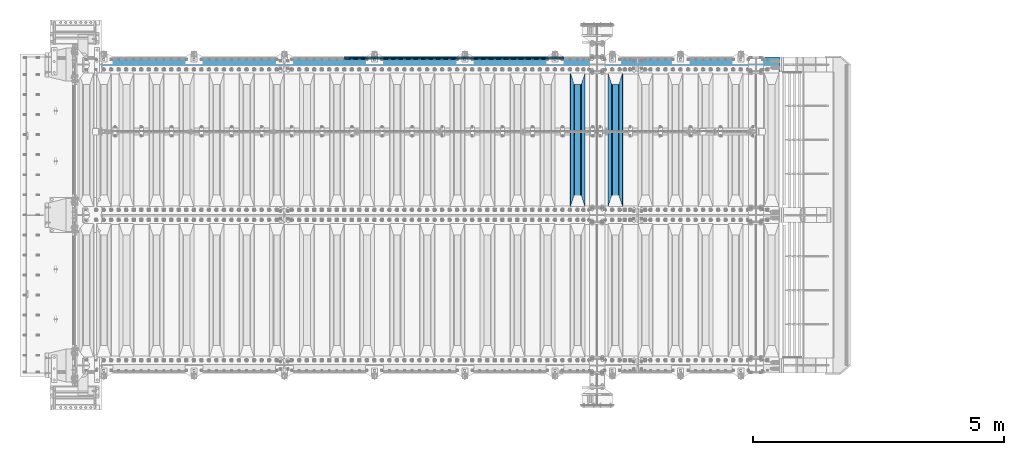
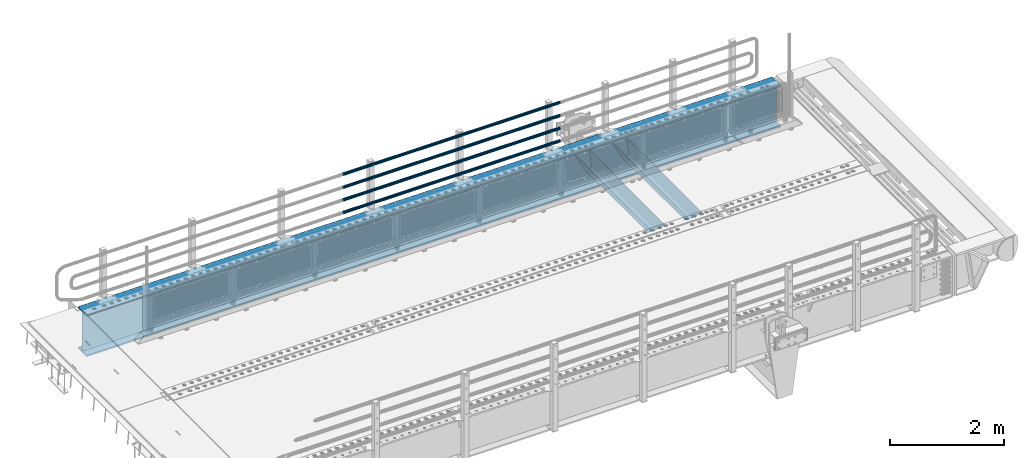
# One storey, part 99 of 193: 7 beams.
"""IFC2X3 building model written with IfcOpenShell, lengths in millimetres."""

import ifcopenshell
import ifcopenshell.guid

model = None  # the IFC model being written
_history = None  # IfcOwnerHistory: only IFC2X3 demands one
_inside = {}  # id of a spatial element -> (the spatial element, [elements in it])
_under = {}  # id of a project, library or spatial element -> (it, [spatial elements below it])
_declared = {}  # id of a project -> (the project, [libraries it declares])
_typed = {}  # id of a type object -> (the type object, [elements of that type])
_made_of = {}  # id of a material, layer set ... -> (it, [elements and type objects made of it])


def new_model(schema):
    """Start an empty IFC model of exactly this schema.

    Asked for "IFC4X3", IfcOpenShell would pick the latest addendum, in which some entities
    have other attributes; the version numbers below select the first issue.
    IFC2X3 requires an IfcOwnerHistory on every rooted entity: one is made here for all.
    """
    global model, _history
    if schema == "IFC4X3":
        model = ifcopenshell.file(schema_version=(4, 3, 0, 0))
    else:
        model = ifcopenshell.file(schema=schema)
    _inside.clear()
    _under.clear()
    _declared.clear()
    _typed.clear()
    _made_of.clear()
    _history = None
    if model.schema == "IFC2X3":
        org = make("IfcOrganization", Name="unknown")
        user = make(
            "IfcPersonAndOrganization",
            ThePerson=make("IfcPerson", FamilyName="unknown"),
            TheOrganization=org,
        )
        app = make(
            "IfcApplication",
            ApplicationDeveloper=org,
            Version="unknown",
            ApplicationFullName="unknown",
            ApplicationIdentifier="unknown",
        )
        _history = make(
            "IfcOwnerHistory",
            OwningUser=user,
            OwningApplication=app,
            ChangeAction="ADDED",
            CreationDate=0,
        )
    return model


def make(cls, **values):
    """One entity of the class cls with the attributes given. An attribute that is None is left unset."""
    return model.create_entity(
        cls, **{name: value for name, value in values.items() if value is not None}
    )


def rooted(cls, **values):
    """An entity with a GlobalId (a new one), such as an element, a storey or a relation."""
    return make(cls, GlobalId=ifcopenshell.guid.new(), OwnerHistory=_history, **values)


def si_unit(unit_type, name, prefix=None):
    """IfcSIUnit, for example si_unit("LENGTHUNIT", "METRE", prefix="MILLI")."""
    return make("IfcSIUnit", UnitType=unit_type, Prefix=prefix, Name=name)


def assignment(units):
    """IfcUnitAssignment: the units of a project."""
    return None if units is None else make("IfcUnitAssignment", Units=units)


def point(xyz):
    """IfcCartesianPoint."""
    return None if xyz is None else make("IfcCartesianPoint", Coordinates=xyz)


def direction(xyz):
    """IfcDirection."""
    return None if xyz is None else make("IfcDirection", DirectionRatios=xyz)


def frame(location, z_axis=None, x_axis=None):
    """IfcAxis2Placement3D, a coordinate frame: its origin and axes. An axis left out is left unset."""
    return make(
        "IfcAxis2Placement3D",
        Location=point(location),
        Axis=direction(z_axis),
        RefDirection=direction(x_axis),
    )


def origin_with_axes():
    """The frame at (0, 0, 0) with the z axis (0, 0, 1) and the x axis (1, 0, 0) written out."""
    return frame((0.0, 0.0, 0.0), z_axis=(0.0, 0.0, 1.0), x_axis=(1.0, 0.0, 0.0))


def place(relative_to, where):
    """IfcLocalPlacement: puts the frame where relative to a parent placement (None: the world)."""
    return make(
        "IfcLocalPlacement", PlacementRelTo=relative_to, RelativePlacement=where
    )


def context(
    kind, dimensions, precision=None, world=None, true_north=None, identifier=None
):
    """IfcGeometricRepresentationContext, for example the 3D "Model" context."""
    return make(
        "IfcGeometricRepresentationContext",
        ContextIdentifier=identifier,
        ContextType=kind,
        CoordinateSpaceDimension=dimensions,
        Precision=precision,
        WorldCoordinateSystem=world,
        TrueNorth=true_north,
    )


def subcontext(parent, identifier, kind, view, scale=None):
    """IfcGeometricRepresentationSubContext, for example "Body" below "Model"."""
    return make(
        "IfcGeometricRepresentationSubContext",
        ContextIdentifier=identifier,
        ContextType=kind,
        ParentContext=parent,
        TargetScale=scale,
        TargetView=view,
    )


def project(units=None, contexts=None):
    """IfcProject with its units and contexts."""
    return rooted(
        "IfcProject",
        Name="project",
        RepresentationContexts=contexts,
        UnitsInContext=assignment(units),
    )


def spatial(cls, under=None, at=None, **own):
    """A site, building, storey or space (cls), placed at a placement, below another one or the project."""
    s = rooted(cls, ObjectPlacement=at, **own)
    if under is not None:
        _under.setdefault(under.id(), (under, []))[1].append(s)
    return s


def faces_of(points, faces, orient=None, outer=None):
    """IfcFace entities. A face is a list of loops; a loop is a list of indices into points, from 0.

    orient and outer hold one flag for each loop. By default every Orientation is true, the
    first loop of a face is its IfcFaceOuterBound and the others are IfcFaceBound.
    """
    made = []
    for i, loops in enumerate(faces):
        bounds = []
        for j, loop in enumerate(loops):
            is_outer = j == 0 if outer is None else outer[i][j]
            bounds.append(
                make(
                    "IfcFaceOuterBound" if is_outer else "IfcFaceBound",
                    Bound=make("IfcPolyLoop", Polygon=[points[k] for k in loop]),
                    Orientation=True if orient is None else orient[i][j],
                )
            )
        made.append(make("IfcFace", Bounds=bounds))
    return made


def faceted_brep(points, faces, orient=None, outer=None, voids=None):
    """IfcFacetedBrep: a solid bounded by flat faces; with voids (closed shells), ...WithVoids."""
    shared = [point(p) for p in points]
    hull = make("IfcClosedShell", CfsFaces=faces_of(shared, faces, orient, outer))
    if voids is None:
        return make("IfcFacetedBrep", Outer=hull)
    return make(
        "IfcFacetedBrepWithVoids",
        Outer=hull,
        Voids=[
            make(cls, CfsFaces=faces_of(shared, fs, o, b)) for cls, fs, o, b in voids
        ],
    )


def shape(context_of_items, identifier, shape_type, items):
    """IfcShapeRepresentation: the items that make up one representation, for example the "Body"."""
    return make(
        "IfcShapeRepresentation",
        ContextOfItems=context_of_items,
        RepresentationIdentifier=identifier,
        RepresentationType=shape_type,
        Items=items,
    )


def material(Name=None, Category=None):
    """IfcMaterial."""
    return make("IfcMaterial", Name=Name, Category=Category)


def made_of(thing, what):
    """Note that an element or type object is made of a material, layer set ...; save() writes the relation."""
    if what is not None:
        _made_of.setdefault(what.id(), (what, []))[1].append(thing)
    return thing


def type_object(cls, material=None, **own):
    """A type object (cls), such as IfcWallType, which elements share."""
    return made_of(rooted(cls, **own), material)


def element(
    cls,
    number,
    at=None,
    inside=None,
    cuts=None,
    type_object=None,
    material=None,
    context=None,
    identifier="Body",
    shape_type=None,
    held_by="IfcProductDefinitionShape",
    body=None,
    shapes=None,
    **own,
):
    """One element of the class cls, such as IfcWall. Its Tag is "e" and its number.

    at: its placement. inside: the storey or other place that contains it. cuts: it is an
    opening in that element (IfcRelVoidsElement). A single representation is given by context,
    identifier, shape_type and body (its items); several are given by shapes. held_by: the class
    of the entity that holds the representations. save() writes the other relations.
    """
    e = rooted(cls, Tag="e%d" % number, ObjectPlacement=at, **own)
    if body is not None:
        shapes = [shape(context, identifier, shape_type, body)]
    if shapes is not None:
        e.Representation = make(held_by, Representations=shapes)
    if inside is not None:
        _inside.setdefault(inside.id(), (inside, []))[1].append(e)
    if cuts is not None:
        rooted(
            "IfcRelVoidsElement", RelatingBuildingElement=cuts, RelatedOpeningElement=e
        )
    if type_object is not None:
        _typed.setdefault(type_object.id(), (type_object, []))[1].append(e)
    return made_of(e, material)


def aggregate(whole, parts):
    """IfcRelAggregates: a whole, such as a stair, and the parts it consists of."""
    return rooted("IfcRelAggregates", RelatingObject=whole, RelatedObjects=parts)


def save(model, path):
    """Write the relations noted so far, then the file.

    IfcRelAggregates (storeys below a building ...), IfcRelContainedInSpatialStructure (elements
    in a storey), IfcRelDefinesByType, IfcRelAssociatesMaterial and IfcRelDeclares: one each for
    every whole, place, type object, material and project.
    """
    for whole, parts in _under.values():
        aggregate(whole, parts)
    for where, things in _inside.values():
        rooted(
            "IfcRelContainedInSpatialStructure",
            RelatedElements=things,
            RelatingStructure=where,
        )
    for kind, things in _typed.values():
        rooted("IfcRelDefinesByType", RelatedObjects=things, RelatingType=kind)
    for what, things in _made_of.values():
        rooted("IfcRelAssociatesMaterial", RelatedObjects=things, RelatingMaterial=what)
    for by, libraries in _declared.values():
        rooted("IfcRelDeclares", RelatingContext=by, RelatedDefinitions=libraries)
    model.write(path)


model = new_model("IFC2X3")

# Units and contexts
model_context = context("Model", 3, precision=1e-05, world=origin_with_axes())
body_context = subcontext(model_context, "Body", "Model", "MODEL_VIEW")
ifc_project = project(units=[si_unit("LENGTHUNIT", "METRE", prefix="MILLI"), si_unit("AREAUNIT", "SQUARE_METRE"), si_unit("VOLUMEUNIT", "CUBIC_METRE"), si_unit("MASSUNIT", "GRAM", prefix="KILO"), si_unit("TIMEUNIT", "SECOND"), si_unit("PLANEANGLEUNIT", "RADIAN"), si_unit("SOLIDANGLEUNIT", "STERADIAN"), si_unit("THERMODYNAMICTEMPERATUREUNIT", "DEGREE_CELSIUS"), si_unit("LUMINOUSINTENSITYUNIT", "LUMEN")], contexts=[model_context])

# Site, building, storey
site_placement = place(None, origin_with_axes())
site = spatial("IfcSite", under=ifc_project, at=site_placement, CompositionType="ELEMENT")
building_placement = place(site_placement, origin_with_axes())
building = spatial("IfcBuilding", under=site, at=building_placement, Name="Standard", CompositionType="ELEMENT")
storey_placement = place(building_placement, origin_with_axes())
storey = spatial("IfcBuildingStorey", under=building, at=storey_placement, Name="Undefined", CompositionType="ELEMENT", Elevation=0.0)

# Beams
ifc_material_1 = material(Name="STEEL/S355N")
beam_type_1 = type_object("IfcBeamType", PredefinedType="NOTDEFINED")
beam_1_placement = place(storey_placement, frame((-31700.0, 27175.0, -115.0), z_axis=(0.0, 0.0, 1.0), x_axis=(0.0, 1.0, 0.0)))
element("IfcBeam", 1, at=beam_1_placement, inside=storey, type_object=beam_type_1, material=ifc_material_1, context=body_context, shape_type="Brep", body=[
    faceted_brep([(0.0, 150.0, 115.0), (0.0, 143.689999999999, 115.0), (2650.00000000297, 143.689999999999, 115.0), (2650.00000000297, 150.0, 115.0), (2650.00000000297, 142.059565218398, 110.000000003094), (2650.00000000297, 148.3695652184, 110.000000003094), (2441.90079219209, -80.1103600731112, -98.0992078077845), (2437.7588105432, -77.5672621345584, -102.241189456673), (2434.06523489747, -74.4080125315522, -105.934765102404), (2430.9108609509, -70.710272125576, -109.089139048974), (2428.37322971128, -66.5649389910068, -111.626770288588), (2426.51472138055, -62.0739139532889, -113.485278619323), (2425.38102192092, -57.3475956567672, -114.618978078955), (2424.99999999988, -52.5021667386536, -115.0), (2424.99999999988, 52.5021667386536, -115.0), (2425.38102192092, 57.3475956567672, -114.618978078955), (2426.51472138055, 62.0739139532889, -113.485278619323), (2428.37322971128, 66.5649389910068, -111.626770288588), (2430.9108609509, 70.710272125576, -109.089139048974), (2434.06523489747, 74.4080125315522, -105.934765102404), (2437.7588105432, 77.5672621345584, -102.241189456673), (2441.90079219209, 80.1103600731112, -98.0992078077846), (2446.38936140512, 81.9747917625791, -93.6106385947584), (2448.2494850041, 76.2713538057251, -91.7505149957729), (2444.62967112263, 74.76777986261, -95.3703288772456), (2441.28936334127, 72.7168944282894, -98.710636658607), (2438.31067330439, 70.1691124903846, -101.689326695487), (2435.76682334748, 67.1870637758839, -104.233176652398), (2433.72034654134, 63.8440531834895, -106.279653458539), (2432.22154950042, 60.222258798236, -107.778450499454), (2431.30727574265, 56.4107117849089, -108.692724257221), (2430.99999999987, 52.5031078186876, -109.0), (2430.99999999987, -52.5031078186876, -109.0), (2431.30727574265, -56.4107117849089, -108.692724257221), (2432.22154950042, -60.222258798236, -107.778450499454), (2433.72034654134, -63.8440531834895, -106.279653458539), (2435.76682334748, -67.1870637758839, -104.233176652398), (2438.31067330439, -70.1691124903846, -101.689326695487), (2441.28936334127, -72.7168944282894, -98.7106366586071), (2444.62967112263, -74.76777986261, -95.3703288772457), (2448.2494850041, -76.2713538057251, -91.7505149957729), (2650.00000000297, -142.059565218398, 110.000000003094), (2650.00000000297, -148.3695652184, 110.000000003094), (2446.38936140512, -81.9747917625791, -93.6106385947584), (2650.00000000297, -143.689999999999, 115.0), (2650.00000000297, -150.0, 115.0), (0.0, -143.689999999999, 115.0), (0.0, -150.0, 115.0), (0.0, -148.369565218261, 110.000000002667), (203.610638597427, -81.9747917625791, -93.6106385947584), (208.099207810446, -80.1103600731112, -98.0992078077845), (212.241189459342, -77.5672621345584, -102.241189456673), (215.93476510507, -74.4080125315522, -105.934765102404), (219.089139051641, -70.710272125576, -109.089139048974), (221.626770291256, -66.5649389910068, -111.626770288588), (223.485278621989, -62.0739139532889, -113.485278619323), (224.618978081624, -57.3475956567672, -114.618978078955), (225.000000002663, -52.5021667386536, -115.0), (225.000000002663, 52.5021667386536, -115.0), (224.618978081624, 57.3475956567672, -114.618978078955), (223.485278621989, 62.0739139532889, -113.485278619323), (221.626770291256, 66.5649389910068, -111.626770288588), (219.089139051641, 70.710272125576, -109.089139048974), (215.93476510507, 74.4080125315522, -105.934765102404), (212.241189459342, 77.5672621345584, -102.241189456673), (208.099207810446, 80.1103600731112, -98.0992078077846), (203.610638597427, 81.9747917625791, -93.6106385947584), (0.0, 148.369565218261, 110.000000002667), (0.0, 142.05956521826, 110.000000002667), (201.750514998439, 76.2713538057251, -91.7505149957729), (205.370328879915, 74.76777986261, -95.3703288772456), (208.710636661275, 72.7168944282894, -98.710636658607), (211.689326698157, 70.1691124903846, -101.689326695487), (214.233176655063, 67.1870637758839, -104.233176652398), (216.279653461206, 63.8440531834895, -106.279653458539), (217.778450502123, 60.222258798236, -107.778450499454), (218.69272425989, 56.4107117849089, -108.692724257221), (219.00000000267, 52.5031078186876, -109.0), (219.00000000267, -52.5031078186876, -109.0), (218.69272425989, -56.4107117849089, -108.692724257221), (217.778450502123, -60.222258798236, -107.778450499454), (216.279653461206, -63.8440531834895, -106.279653458539), (214.233176655063, -67.1870637758839, -104.233176652398), (211.689326698157, -70.1691124903846, -101.689326695487), (208.710636661275, -72.7168944282894, -98.7106366586071), (205.370328879915, -74.76777986261, -95.3703288772457), (201.750514998439, -76.2713538057251, -91.7505149957729), (0.0, -142.05956521826, 110.000000002667)], [[[0, 1, 2, 3]], [[3, 2, 4, 5]], [[6, 7, 8, 9, 10, 11, 12, 13, 14, 15, 16, 17, 18, 19, 20, 21, 22, 5, 4, 23, 24, 25, 26, 27, 28, 29, 30, 31, 32, 33, 34, 35, 36, 37, 38, 39, 40, 41, 42, 43]], [[44, 45, 42, 41]], [[46, 47, 45, 44]], [[43, 42, 45, 47, 48, 49]], [[6, 43, 49, 50]], [[7, 6, 50, 51]], [[8, 7, 51, 52]], [[9, 8, 52, 53]], [[10, 9, 53, 54]], [[11, 10, 54, 55]], [[12, 11, 55, 56]], [[13, 12, 56, 57]], [[14, 13, 57, 58]], [[15, 14, 58, 59]], [[16, 15, 59, 60]], [[17, 16, 60, 61]], [[18, 17, 61, 62]], [[19, 18, 62, 63]], [[20, 19, 63, 64]], [[21, 20, 64, 65]], [[22, 21, 65, 66]], [[0, 3, 5, 22, 66, 67]], [[1, 0, 67, 68]], [[23, 4, 2, 1, 68, 69]], [[24, 23, 69, 70]], [[25, 24, 70, 71]], [[26, 25, 71, 72]], [[27, 26, 72, 73]], [[28, 27, 73, 74]], [[29, 28, 74, 75]], [[30, 29, 75, 76]], [[31, 30, 76, 77]], [[32, 31, 77, 78]], [[33, 32, 78, 79]], [[34, 33, 79, 80]], [[35, 34, 80, 81]], [[36, 35, 81, 82]], [[37, 36, 82, 83]], [[38, 37, 83, 84]], [[39, 38, 84, 85]], [[40, 39, 85, 86]], [[46, 44, 41, 40, 86, 87]], [[47, 46, 87, 48]], [[86, 85, 84, 83, 82, 81, 80, 79, 78, 77, 76, 75, 74, 73, 72, 71, 70, 69, 68, 67, 66, 65, 64, 63, 62, 61, 60, 59, 58, 57, 56, 55, 54, 53, 52, 51, 50, 49, 48, 87]]]),
])
beam_2_placement = place(storey_placement, frame((-32450.0, 27175.0, -115.0), z_axis=(0.0, 0.0, 1.0), x_axis=(0.0, 1.0, 0.0)))
element("IfcBeam", 2, at=beam_2_placement, inside=storey, type_object=beam_type_1, material=ifc_material_1, context=body_context, shape_type="Brep", body=[
    faceted_brep([(0.0, 150.0, 115.0), (0.0, 143.689999999999, 115.0), (2650.00000000297, 143.689999999999, 115.0), (2650.00000000297, 150.0, 115.0), (2650.00000000297, 142.059565218398, 110.000000003094), (2650.00000000297, 148.3695652184, 110.000000003094), (2441.90079219209, -80.1103600731112, -98.0992078077845), (2437.7588105432, -77.5672621345584, -102.241189456673), (2434.06523489747, -74.4080125315522, -105.934765102404), (2430.9108609509, -70.710272125576, -109.089139048974), (2428.37322971128, -66.5649389910068, -111.626770288588), (2426.51472138055, -62.0739139532889, -113.485278619323), (2425.38102192092, -57.3475956567672, -114.618978078955), (2424.99999999988, -52.5021667386536, -115.0), (2424.99999999988, 52.5021667386536, -115.0), (2425.38102192092, 57.3475956567672, -114.618978078955), (2426.51472138055, 62.0739139532889, -113.485278619323), (2428.37322971128, 66.5649389910068, -111.626770288588), (2430.9108609509, 70.710272125576, -109.089139048974), (2434.06523489747, 74.4080125315522, -105.934765102404), (2437.7588105432, 77.5672621345584, -102.241189456673), (2441.90079219209, 80.1103600731112, -98.0992078077846), (2446.38936140512, 81.9747917625791, -93.6106385947584), (2448.2494850041, 76.2713538057251, -91.7505149957729), (2444.62967112263, 74.76777986261, -95.3703288772456), (2441.28936334127, 72.7168944282894, -98.710636658607), (2438.31067330439, 70.1691124903846, -101.689326695487), (2435.76682334748, 67.1870637758839, -104.233176652398), (2433.72034654134, 63.8440531834895, -106.279653458539), (2432.22154950042, 60.222258798236, -107.778450499454), (2431.30727574265, 56.4107117849089, -108.692724257221), (2430.99999999987, 52.5031078186876, -109.0), (2430.99999999987, -52.5031078186876, -109.0), (2431.30727574265, -56.4107117849089, -108.692724257221), (2432.22154950042, -60.222258798236, -107.778450499454), (2433.72034654134, -63.8440531834895, -106.279653458539), (2435.76682334748, -67.1870637758839, -104.233176652398), (2438.31067330439, -70.1691124903846, -101.689326695487), (2441.28936334127, -72.7168944282894, -98.7106366586071), (2444.62967112263, -74.76777986261, -95.3703288772457), (2448.2494850041, -76.2713538057251, -91.7505149957729), (2650.00000000297, -142.059565218398, 110.000000003094), (2650.00000000297, -148.3695652184, 110.000000003094), (2446.38936140512, -81.9747917625791, -93.6106385947584), (2650.00000000297, -143.689999999999, 115.0), (2650.00000000297, -150.0, 115.0), (0.0, -143.689999999999, 115.0), (0.0, -150.0, 115.0), (0.0, -148.369565218261, 110.000000002667), (203.610638597427, -81.9747917625791, -93.6106385947584), (208.099207810446, -80.1103600731112, -98.0992078077845), (212.241189459342, -77.5672621345584, -102.241189456673), (215.93476510507, -74.4080125315522, -105.934765102404), (219.089139051641, -70.710272125576, -109.089139048974), (221.626770291256, -66.5649389910068, -111.626770288588), (223.485278621989, -62.0739139532889, -113.485278619323), (224.618978081624, -57.3475956567672, -114.618978078955), (225.000000002663, -52.5021667386536, -115.0), (225.000000002663, 52.5021667386536, -115.0), (224.618978081624, 57.3475956567672, -114.618978078955), (223.485278621989, 62.0739139532889, -113.485278619323), (221.626770291256, 66.5649389910068, -111.626770288588), (219.089139051641, 70.710272125576, -109.089139048974), (215.93476510507, 74.4080125315522, -105.934765102404), (212.241189459342, 77.5672621345584, -102.241189456673), (208.099207810446, 80.1103600731112, -98.0992078077846), (203.610638597427, 81.9747917625791, -93.6106385947584), (0.0, 148.369565218261, 110.000000002667), (0.0, 142.05956521826, 110.000000002667), (201.750514998439, 76.2713538057251, -91.7505149957729), (205.370328879915, 74.76777986261, -95.3703288772456), (208.710636661275, 72.7168944282894, -98.710636658607), (211.689326698157, 70.1691124903846, -101.689326695487), (214.233176655063, 67.1870637758839, -104.233176652398), (216.279653461206, 63.8440531834895, -106.279653458539), (217.778450502123, 60.222258798236, -107.778450499454), (218.69272425989, 56.4107117849089, -108.692724257221), (219.00000000267, 52.5031078186876, -109.0), (219.00000000267, -52.5031078186876, -109.0), (218.69272425989, -56.4107117849089, -108.692724257221), (217.778450502123, -60.222258798236, -107.778450499454), (216.279653461206, -63.8440531834895, -106.279653458539), (214.233176655063, -67.1870637758839, -104.233176652398), (211.689326698157, -70.1691124903846, -101.689326695487), (208.710636661275, -72.7168944282894, -98.7106366586071), (205.370328879915, -74.76777986261, -95.3703288772457), (201.750514998439, -76.2713538057251, -91.7505149957729), (0.0, -142.05956521826, 110.000000002667)], [[[0, 1, 2, 3]], [[3, 2, 4, 5]], [[6, 7, 8, 9, 10, 11, 12, 13, 14, 15, 16, 17, 18, 19, 20, 21, 22, 5, 4, 23, 24, 25, 26, 27, 28, 29, 30, 31, 32, 33, 34, 35, 36, 37, 38, 39, 40, 41, 42, 43]], [[44, 45, 42, 41]], [[46, 47, 45, 44]], [[43, 42, 45, 47, 48, 49]], [[6, 43, 49, 50]], [[7, 6, 50, 51]], [[8, 7, 51, 52]], [[9, 8, 52, 53]], [[10, 9, 53, 54]], [[11, 10, 54, 55]], [[12, 11, 55, 56]], [[13, 12, 56, 57]], [[14, 13, 57, 58]], [[15, 14, 58, 59]], [[16, 15, 59, 60]], [[17, 16, 60, 61]], [[18, 17, 61, 62]], [[19, 18, 62, 63]], [[20, 19, 63, 64]], [[21, 20, 64, 65]], [[22, 21, 65, 66]], [[0, 3, 5, 22, 66, 67]], [[1, 0, 67, 68]], [[23, 4, 2, 1, 68, 69]], [[24, 23, 69, 70]], [[25, 24, 70, 71]], [[26, 25, 71, 72]], [[27, 26, 72, 73]], [[28, 27, 73, 74]], [[29, 28, 74, 75]], [[30, 29, 75, 76]], [[31, 30, 76, 77]], [[32, 31, 77, 78]], [[33, 32, 78, 79]], [[34, 33, 79, 80]], [[35, 34, 80, 81]], [[36, 35, 81, 82]], [[37, 36, 82, 83]], [[38, 37, 83, 84]], [[39, 38, 84, 85]], [[40, 39, 85, 86]], [[46, 44, 41, 40, 86, 87]], [[47, 46, 87, 48]], [[86, 85, 84, 83, 82, 81, 80, 79, 78, 77, 76, 75, 74, 73, 72, 71, 70, 69, 68, 67, 66, 65, 64, 63, 62, 61, 60, 59, 58, 57, 56, 55, 54, 53, 52, 51, 50, 49, 48, 87]]]),
])
ifc_material_2 = material()
beam_type_2 = type_object("IfcBeamType", PredefinedType="NOTDEFINED")
beam_3_placement = place(storey_placement, frame((-32722.0000000001, 30129.8500000001, 149.849999999748), z_axis=(0.0, 0.0, -1.0), x_axis=(-1.0, 0.0, 0.0)))
element("IfcBeam", 3, at=beam_3_placement, inside=storey, type_object=beam_type_2, material=ifc_material_2, context=body_context, shape_type="Brep", body=[
    faceted_brep([(0.0, -26.5499999999993, 0.0), (0.0, -24.5290015881765, 10.1602451292931), (4384.00249699992, -24.5290015881765, 10.1602451292931), (4384.00249699992, -26.5499999999993, 0.0), (0.0, -18.7736850405017, 18.7736850405028), (4384.00249699992, -18.7736850405017, 18.7736850405028), (0.0, -10.1602451292929, 24.5290015881747), (4384.00249699992, -10.1602451292929, 24.5290015881747), (0.0, 0.0, 26.55), (4384.00249699992, 0.0, 26.55), (0.0, 10.1602451292929, 24.5290015881747), (4384.00249699992, 10.1602451292929, 24.5290015881747), (0.0, 18.7736850405017, 18.7736850405028), (4384.00249699992, 18.7736850405017, 18.7736850405028), (0.0, 24.5290015881765, 10.1602451292931), (4384.00249699992, 24.5290015881765, 10.1602451292931), (0.0, 26.5499999999993, 0.0), (4384.00249699992, 26.5499999999993, 0.0), (0.0, 24.5290015881765, -10.1602451292931), (4384.00249699992, 24.5290015881765, -10.1602451292931), (0.0, 18.7736850405017, -18.7736850405028), (4384.00249699992, 18.7736850405017, -18.7736850405028), (0.0, 10.1602451292929, -24.5290015881747), (4384.00249699992, 10.1602451292929, -24.5290015881747), (0.0, 0.0, -26.55), (4384.00249699992, 0.0, -26.55), (0.0, -10.1602451292929, -24.5290015881747), (4384.00249699992, -10.1602451292929, -24.5290015881747), (0.0, -18.7736850405017, -18.7736850405028), (4384.00249699992, -18.7736850405017, -18.7736850405028), (0.0, -24.5290015881765, -10.1602451292931), (4384.00249699992, -24.5290015881765, -10.1602451292931), (0.0, -30.1500000000015, 0.0), (0.0, -27.8549679052157, -11.5379054858058), (4384.00249699992, -27.8549679052157, -11.5379054858075), (4384.00249699992, -30.1500000000015, 0.0), (0.0, -21.3192694527752, -21.3192694527752), (4384.00249699992, -21.3192694527752, -21.3192694527744), (0.0, -11.5379054858058, -27.8549679052157), (4384.00249699992, -11.5379054858058, -27.8549679052153), (0.0, 0.0, -30.1500000000015), (4384.00249699992, 0.0, -30.15), (0.0, 11.5379054858058, -27.8549679052157), (4384.00249699992, 11.5379054858058, -27.8549679052153), (0.0, 21.3192694527752, -21.3192694527752), (4384.00249699992, 21.3192694527752, -21.3192694527744), (0.0, 27.8549679052157, -11.5379054858058), (4384.00249699992, 27.8549679052157, -11.5379054858074), (0.0, 30.1500000000015, 0.0), (4384.00249699992, 30.1500000000015, 0.0), (0.0, 27.8549679052157, 11.5379054858058), (4384.00249699992, 27.8549679052157, 11.5379054858075), (0.0, 21.3192694527752, 21.3192694527752), (4384.00249699992, 21.3192694527752, 21.3192694527744), (0.0, 11.5379054858058, 27.8549679052157), (4384.00249699992, 11.5379054858058, 27.8549679052153), (0.0, 0.0, 30.1500000000015), (4384.00249699992, 0.0, 30.15), (0.0, -11.5379054858058, 27.8549679052157), (4384.00249699992, -11.5379054858058, 27.8549679052153), (0.0, -21.3192694527752, 21.3192694527752), (4384.00249699992, -21.3192694527752, 21.3192694527744), (0.0, -27.8549679052157, 11.5379054858058), (4384.00249699992, -27.8549679052157, 11.5379054858075)], [[[0, 1, 2, 3]], [[1, 4, 5, 2]], [[4, 6, 7, 5]], [[6, 8, 9, 7]], [[8, 10, 11, 9]], [[10, 12, 13, 11]], [[12, 14, 15, 13]], [[14, 16, 17, 15]], [[16, 18, 19, 17]], [[18, 20, 21, 19]], [[20, 22, 23, 21]], [[22, 24, 25, 23]], [[24, 26, 27, 25]], [[26, 28, 29, 27]], [[28, 30, 31, 29]], [[30, 0, 3, 31]], [[32, 33, 34, 35]], [[33, 36, 37, 34]], [[36, 38, 39, 37]], [[38, 40, 41, 39]], [[40, 42, 43, 41]], [[42, 44, 45, 43]], [[44, 46, 47, 45]], [[46, 48, 49, 47]], [[48, 50, 51, 49]], [[50, 52, 53, 51]], [[52, 54, 55, 53]], [[54, 56, 57, 55]], [[56, 58, 59, 57]], [[58, 60, 61, 59]], [[60, 62, 63, 61]], [[62, 32, 35, 63]], [[37, 39, 41, 43, 45, 47, 49, 51, 53, 55, 57, 59, 61, 63, 35, 34], [5, 7, 9, 11, 13, 15, 17, 19, 21, 23, 25, 27, 29, 31, 3, 2]], [[62, 60, 58, 56, 54, 52, 50, 48, 46, 44, 42, 40, 38, 36, 33, 32], [30, 28, 26, 24, 22, 20, 18, 16, 14, 12, 10, 8, 6, 4, 1, 0]]]),
])
beam_4_placement = place(storey_placement, frame((-32722.0000000001, 30129.8500000001, 420.149999999748), z_axis=(0.0, 0.0, -1.0), x_axis=(-1.0, 0.0, 0.0)))
element("IfcBeam", 4, at=beam_4_placement, inside=storey, type_object=beam_type_2, material=ifc_material_2, context=body_context, shape_type="Brep", body=[
    faceted_brep([(0.0, -26.5499999999993, 0.0), (0.0, -24.5290015881765, 10.1602451292931), (4384.00249699992, -24.5290015881765, 10.1602451292931), (4384.00249699992, -26.5499999999993, 0.0), (0.0, -18.7736850405017, 18.7736850405028), (4384.00249699992, -18.7736850405017, 18.7736850405028), (0.0, -10.1602451292929, 24.5290015881747), (4384.00249699992, -10.1602451292929, 24.5290015881747), (0.0, 0.0, 26.55), (4384.00249699992, 0.0, 26.55), (0.0, 10.1602451292929, 24.5290015881747), (4384.00249699992, 10.1602451292929, 24.5290015881747), (0.0, 18.7736850405017, 18.7736850405028), (4384.00249699992, 18.7736850405017, 18.7736850405028), (0.0, 24.5290015881765, 10.1602451292931), (4384.00249699992, 24.5290015881765, 10.1602451292931), (0.0, 26.5499999999993, 0.0), (4384.00249699992, 26.5499999999993, 0.0), (0.0, 24.5290015881765, -10.1602451292931), (4384.00249699992, 24.5290015881765, -10.1602451292931), (0.0, 18.7736850405017, -18.7736850405028), (4384.00249699992, 18.7736850405017, -18.7736850405028), (0.0, 10.1602451292929, -24.5290015881747), (4384.00249699992, 10.1602451292929, -24.5290015881747), (0.0, 0.0, -26.55), (4384.00249699992, 0.0, -26.55), (0.0, -10.1602451292929, -24.5290015881747), (4384.00249699992, -10.1602451292929, -24.5290015881747), (0.0, -18.7736850405017, -18.7736850405028), (4384.00249699992, -18.7736850405017, -18.7736850405028), (0.0, -24.5290015881765, -10.1602451292931), (4384.00249699992, -24.5290015881765, -10.1602451292931), (0.0, -30.1500000000015, 0.0), (0.0, -27.8549679052157, -11.5379054858058), (4384.00249699992, -27.8549679052157, -11.5379054858075), (4384.00249699992, -30.1500000000015, 0.0), (0.0, -21.3192694527752, -21.3192694527752), (4384.00249699992, -21.3192694527752, -21.3192694527744), (0.0, -11.5379054858058, -27.8549679052157), (4384.00249699992, -11.5379054858058, -27.8549679052153), (0.0, 0.0, -30.1500000000015), (4384.00249699992, 0.0, -30.15), (0.0, 11.5379054858058, -27.8549679052157), (4384.00249699992, 11.5379054858058, -27.8549679052153), (0.0, 21.3192694527752, -21.3192694527752), (4384.00249699992, 21.3192694527752, -21.3192694527744), (0.0, 27.8549679052157, -11.5379054858058), (4384.00249699992, 27.8549679052157, -11.5379054858074), (0.0, 30.1500000000015, 0.0), (4384.00249699992, 30.1500000000015, 0.0), (0.0, 27.8549679052157, 11.5379054858058), (4384.00249699992, 27.8549679052157, 11.5379054858075), (0.0, 21.3192694527752, 21.3192694527752), (4384.00249699992, 21.3192694527752, 21.3192694527744), (0.0, 11.5379054858058, 27.8549679052157), (4384.00249699992, 11.5379054858058, 27.8549679052153), (0.0, 0.0, 30.1500000000015), (4384.00249699992, 0.0, 30.15), (0.0, -11.5379054858058, 27.8549679052157), (4384.00249699992, -11.5379054858058, 27.8549679052153), (0.0, -21.3192694527752, 21.3192694527752), (4384.00249699992, -21.3192694527752, 21.3192694527744), (0.0, -27.8549679052157, 11.5379054858058), (4384.00249699992, -27.8549679052157, 11.5379054858075)], [[[0, 1, 2, 3]], [[1, 4, 5, 2]], [[4, 6, 7, 5]], [[6, 8, 9, 7]], [[8, 10, 11, 9]], [[10, 12, 13, 11]], [[12, 14, 15, 13]], [[14, 16, 17, 15]], [[16, 18, 19, 17]], [[18, 20, 21, 19]], [[20, 22, 23, 21]], [[22, 24, 25, 23]], [[24, 26, 27, 25]], [[26, 28, 29, 27]], [[28, 30, 31, 29]], [[30, 0, 3, 31]], [[32, 33, 34, 35]], [[33, 36, 37, 34]], [[36, 38, 39, 37]], [[38, 40, 41, 39]], [[40, 42, 43, 41]], [[42, 44, 45, 43]], [[44, 46, 47, 45]], [[46, 48, 49, 47]], [[48, 50, 51, 49]], [[50, 52, 53, 51]], [[52, 54, 55, 53]], [[54, 56, 57, 55]], [[56, 58, 59, 57]], [[58, 60, 61, 59]], [[60, 62, 63, 61]], [[62, 32, 35, 63]], [[37, 39, 41, 43, 45, 47, 49, 51, 53, 55, 57, 59, 61, 63, 35, 34], [5, 7, 9, 11, 13, 15, 17, 19, 21, 23, 25, 27, 29, 31, 3, 2]], [[62, 60, 58, 56, 54, 52, 50, 48, 46, 44, 42, 40, 38, 36, 33, 32], [30, 28, 26, 24, 22, 20, 18, 16, 14, 12, 10, 8, 6, 4, 1, 0]]]),
])
beam_5_placement = place(storey_placement, frame((-32722.0000000001, 30129.8500000001, 969.849999999748), z_axis=(0.0, 0.0, -1.0), x_axis=(-1.0, 0.0, 0.0)))
element("IfcBeam", 5, at=beam_5_placement, inside=storey, type_object=beam_type_2, material=ifc_material_2, context=body_context, shape_type="Brep", body=[
    faceted_brep([(0.0, -26.5499999999993, 0.0), (0.0, -24.5290015881765, 10.1602451292931), (4384.00249699992, -24.5290015881765, 10.1602451292931), (4384.00249699992, -26.5499999999993, 0.0), (0.0, -18.7736850405017, 18.7736850405028), (4384.00249699992, -18.7736850405017, 18.7736850405028), (0.0, -10.1602451292929, 24.5290015881747), (4384.00249699992, -10.1602451292929, 24.5290015881747), (0.0, 0.0, 26.55), (4384.00249699992, 0.0, 26.55), (0.0, 10.1602451292929, 24.5290015881747), (4384.00249699992, 10.1602451292929, 24.5290015881747), (0.0, 18.7736850405017, 18.7736850405028), (4384.00249699992, 18.7736850405017, 18.7736850405028), (0.0, 24.5290015881765, 10.1602451292931), (4384.00249699992, 24.5290015881765, 10.1602451292931), (0.0, 26.5499999999993, 0.0), (4384.00249699992, 26.5499999999993, 0.0), (0.0, 24.5290015881765, -10.1602451292931), (4384.00249699992, 24.5290015881765, -10.1602451292931), (0.0, 18.7736850405017, -18.7736850405028), (4384.00249699992, 18.7736850405017, -18.7736850405028), (0.0, 10.1602451292929, -24.5290015881747), (4384.00249699992, 10.1602451292929, -24.5290015881747), (0.0, 0.0, -26.55), (4384.00249699992, 0.0, -26.55), (0.0, -10.1602451292929, -24.5290015881747), (4384.00249699992, -10.1602451292929, -24.5290015881747), (0.0, -18.7736850405017, -18.7736850405028), (4384.00249699992, -18.7736850405017, -18.7736850405028), (0.0, -24.5290015881765, -10.1602451292931), (4384.00249699992, -24.5290015881765, -10.1602451292931), (0.0, -30.1500000000015, 0.0), (0.0, -27.8549679052157, -11.5379054858058), (4384.00249699992, -27.8549679052157, -11.5379054858075), (4384.00249699992, -30.1500000000015, 0.0), (0.0, -21.3192694527752, -21.3192694527752), (4384.00249699992, -21.3192694527752, -21.3192694527744), (0.0, -11.5379054858058, -27.8549679052157), (4384.00249699992, -11.5379054858058, -27.8549679052153), (0.0, 0.0, -30.1500000000015), (4384.00249699992, 0.0, -30.15), (0.0, 11.5379054858058, -27.8549679052157), (4384.00249699992, 11.5379054858058, -27.8549679052153), (0.0, 21.3192694527752, -21.3192694527752), (4384.00249699992, 21.3192694527752, -21.3192694527744), (0.0, 27.8549679052157, -11.5379054858058), (4384.00249699992, 27.8549679052157, -11.5379054858074), (0.0, 30.1500000000015, 0.0), (4384.00249699992, 30.1500000000015, 0.0), (0.0, 27.8549679052157, 11.5379054858058), (4384.00249699992, 27.8549679052157, 11.5379054858075), (0.0, 21.3192694527752, 21.3192694527752), (4384.00249699992, 21.3192694527752, 21.3192694527744), (0.0, 11.5379054858058, 27.8549679052157), (4384.00249699992, 11.5379054858058, 27.8549679052153), (0.0, 0.0, 30.1500000000015), (4384.00249699992, 0.0, 30.15), (0.0, -11.5379054858058, 27.8549679052157), (4384.00249699992, -11.5379054858058, 27.8549679052153), (0.0, -21.3192694527752, 21.3192694527752), (4384.00249699992, -21.3192694527752, 21.3192694527744), (0.0, -27.8549679052157, 11.5379054858058), (4384.00249699992, -27.8549679052157, 11.5379054858075)], [[[0, 1, 2, 3]], [[1, 4, 5, 2]], [[4, 6, 7, 5]], [[6, 8, 9, 7]], [[8, 10, 11, 9]], [[10, 12, 13, 11]], [[12, 14, 15, 13]], [[14, 16, 17, 15]], [[16, 18, 19, 17]], [[18, 20, 21, 19]], [[20, 22, 23, 21]], [[22, 24, 25, 23]], [[24, 26, 27, 25]], [[26, 28, 29, 27]], [[28, 30, 31, 29]], [[30, 0, 3, 31]], [[32, 33, 34, 35]], [[33, 36, 37, 34]], [[36, 38, 39, 37]], [[38, 40, 41, 39]], [[40, 42, 43, 41]], [[42, 44, 45, 43]], [[44, 46, 47, 45]], [[46, 48, 49, 47]], [[48, 50, 51, 49]], [[50, 52, 53, 51]], [[52, 54, 55, 53]], [[54, 56, 57, 55]], [[56, 58, 59, 57]], [[58, 60, 61, 59]], [[60, 62, 63, 61]], [[62, 32, 35, 63]], [[37, 39, 41, 43, 45, 47, 49, 51, 53, 55, 57, 59, 61, 63, 35, 34], [5, 7, 9, 11, 13, 15, 17, 19, 21, 23, 25, 27, 29, 31, 3, 2]], [[62, 60, 58, 56, 54, 52, 50, 48, 46, 44, 42, 40, 38, 36, 33, 32], [30, 28, 26, 24, 22, 20, 18, 16, 14, 12, 10, 8, 6, 4, 1, 0]]]),
])
beam_6_placement = place(storey_placement, frame((-32722.0000000001, 30129.8500000001, 689.849999999748), z_axis=(0.0, 0.0, -1.0), x_axis=(-1.0, 0.0, 0.0)))
element("IfcBeam", 6, at=beam_6_placement, inside=storey, type_object=beam_type_2, material=ifc_material_2, context=body_context, shape_type="Brep", body=[
    faceted_brep([(0.0, -26.5499999999993, 0.0), (0.0, -24.5290015881765, 10.1602451292931), (4384.00249699992, -24.5290015881765, 10.1602451292931), (4384.00249699992, -26.5499999999993, 0.0), (0.0, -18.7736850405017, 18.7736850405028), (4384.00249699992, -18.7736850405017, 18.7736850405028), (0.0, -10.1602451292929, 24.5290015881747), (4384.00249699992, -10.1602451292929, 24.5290015881747), (0.0, 0.0, 26.55), (4384.00249699992, 0.0, 26.55), (0.0, 10.1602451292929, 24.5290015881747), (4384.00249699992, 10.1602451292929, 24.5290015881747), (0.0, 18.7736850405017, 18.7736850405028), (4384.00249699992, 18.7736850405017, 18.7736850405028), (0.0, 24.5290015881765, 10.1602451292931), (4384.00249699992, 24.5290015881765, 10.1602451292931), (0.0, 26.5499999999993, 0.0), (4384.00249699992, 26.5499999999993, 0.0), (0.0, 24.5290015881765, -10.1602451292931), (4384.00249699992, 24.5290015881765, -10.1602451292931), (0.0, 18.7736850405017, -18.7736850405028), (4384.00249699992, 18.7736850405017, -18.7736850405028), (0.0, 10.1602451292929, -24.5290015881747), (4384.00249699992, 10.1602451292929, -24.5290015881747), (0.0, 0.0, -26.55), (4384.00249699992, 0.0, -26.55), (0.0, -10.1602451292929, -24.5290015881747), (4384.00249699992, -10.1602451292929, -24.5290015881747), (0.0, -18.7736850405017, -18.7736850405028), (4384.00249699992, -18.7736850405017, -18.7736850405028), (0.0, -24.5290015881765, -10.1602451292931), (4384.00249699992, -24.5290015881765, -10.1602451292931), (0.0, -30.1500000000015, 0.0), (0.0, -27.8549679052157, -11.5379054858058), (4384.00249699992, -27.8549679052157, -11.5379054858075), (4384.00249699992, -30.1500000000015, 0.0), (0.0, -21.3192694527752, -21.3192694527752), (4384.00249699992, -21.3192694527752, -21.3192694527744), (0.0, -11.5379054858058, -27.8549679052157), (4384.00249699992, -11.5379054858058, -27.8549679052153), (0.0, 0.0, -30.1500000000015), (4384.00249699992, 0.0, -30.15), (0.0, 11.5379054858058, -27.8549679052157), (4384.00249699992, 11.5379054858058, -27.8549679052153), (0.0, 21.3192694527752, -21.3192694527752), (4384.00249699992, 21.3192694527752, -21.3192694527744), (0.0, 27.8549679052157, -11.5379054858058), (4384.00249699992, 27.8549679052157, -11.5379054858074), (0.0, 30.1500000000015, 0.0), (4384.00249699992, 30.1500000000015, 0.0), (0.0, 27.8549679052157, 11.5379054858058), (4384.00249699992, 27.8549679052157, 11.5379054858075), (0.0, 21.3192694527752, 21.3192694527752), (4384.00249699992, 21.3192694527752, 21.3192694527744), (0.0, 11.5379054858058, 27.8549679052157), (4384.00249699992, 11.5379054858058, 27.8549679052153), (0.0, 0.0, 30.1500000000015), (4384.00249699992, 0.0, 30.15), (0.0, -11.5379054858058, 27.8549679052157), (4384.00249699992, -11.5379054858058, 27.8549679052153), (0.0, -21.3192694527752, 21.3192694527752), (4384.00249699992, -21.3192694527752, 21.3192694527744), (0.0, -27.8549679052157, 11.5379054858058), (4384.00249699992, -27.8549679052157, 11.5379054858075)], [[[0, 1, 2, 3]], [[1, 4, 5, 2]], [[4, 6, 7, 5]], [[6, 8, 9, 7]], [[8, 10, 11, 9]], [[10, 12, 13, 11]], [[12, 14, 15, 13]], [[14, 16, 17, 15]], [[16, 18, 19, 17]], [[18, 20, 21, 19]], [[20, 22, 23, 21]], [[22, 24, 25, 23]], [[24, 26, 27, 25]], [[26, 28, 29, 27]], [[28, 30, 31, 29]], [[30, 0, 3, 31]], [[32, 33, 34, 35]], [[33, 36, 37, 34]], [[36, 38, 39, 37]], [[38, 40, 41, 39]], [[40, 42, 43, 41]], [[42, 44, 45, 43]], [[44, 46, 47, 45]], [[46, 48, 49, 47]], [[48, 50, 51, 49]], [[50, 52, 53, 51]], [[52, 54, 55, 53]], [[54, 56, 57, 55]], [[56, 58, 59, 57]], [[58, 60, 61, 59]], [[60, 62, 63, 61]], [[62, 32, 35, 63]], [[37, 39, 41, 43, 45, 47, 49, 51, 53, 55, 57, 59, 61, 63, 35, 34], [5, 7, 9, 11, 13, 15, 17, 19, 21, 23, 25, 27, 29, 31, 3, 2]], [[62, 60, 58, 56, 54, 52, 50, 48, 46, 44, 42, 40, 38, 36, 33, 32], [30, 28, 26, 24, 22, 20, 18, 16, 14, 12, 10, 8, 6, 4, 1, 0]]]),
])
beam_type_3 = type_object("IfcBeamType", Name="HEA900", PredefinedType="NOTDEFINED")
beam_7_placement = place(storey_placement, frame((-42440.0, 30000.0, -445.0), z_axis=(0.0, 0.0, 1.0), x_axis=(1.0, 0.0, 0.0)))
element("IfcBeam", 7, at=beam_7_placement, inside=storey, type_object=beam_type_3, material=ifc_material_1, ObjectType="HEA900", context=body_context, shape_type="Brep", body=[
    faceted_brep([(0.0, 150.0, -445.0), (0.0, 150.0, -415.0), (14017.0, 150.0, -415.0), (14017.0, 150.0, -445.0), (0.0, 8.0, -415.0), (14017.0, 8.0, -415.0), (0.0, 8.0, 415.0), (14017.0, 8.0, 415.0), (0.0, 150.0, 415.0), (14017.0, 150.0, 415.0), (0.0, 150.0, 445.0), (14017.0, 150.0, 445.0), (0.0, -150.0, 445.0), (14017.0, -150.0, 445.0), (0.0, -150.0, 415.0), (14017.0, -150.0, 415.0), (0.0, -8.0, 415.0), (14017.0, -8.0, 415.0), (0.0, -8.0, -415.0), (14017.0, -8.0, -415.0), (0.0, -150.0, -415.0), (14017.0, -150.0, -415.0), (0.0, -150.0, -445.0), (14017.0, -150.0, -445.0)], [[[0, 1, 2, 3]], [[1, 4, 5, 2]], [[4, 6, 7, 5]], [[6, 8, 9, 7]], [[8, 10, 11, 9]], [[10, 12, 13, 11]], [[12, 14, 15, 13]], [[14, 16, 17, 15]], [[16, 18, 19, 17]], [[18, 20, 21, 19]], [[20, 22, 23, 21]], [[22, 0, 3, 23]], [[5, 7, 9, 11, 13, 15, 17, 19, 21, 23, 3, 2]], [[22, 20, 18, 16, 14, 12, 10, 8, 6, 4, 1, 0]]]),
])

save(model, "model.ifc")
